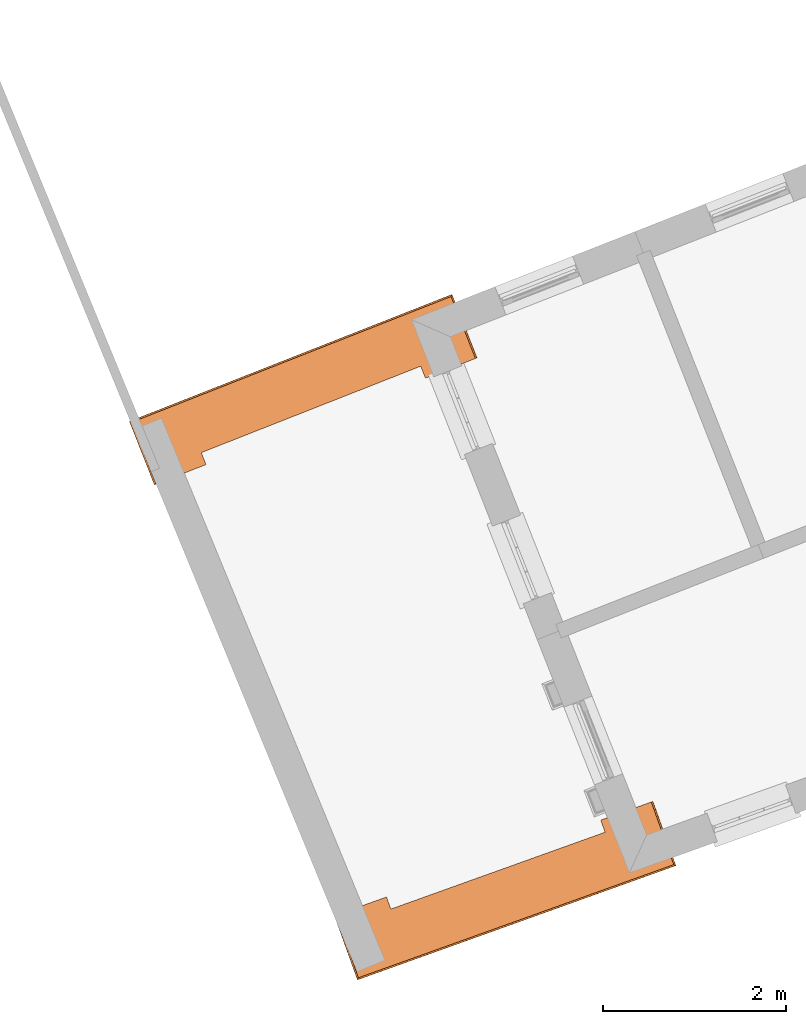
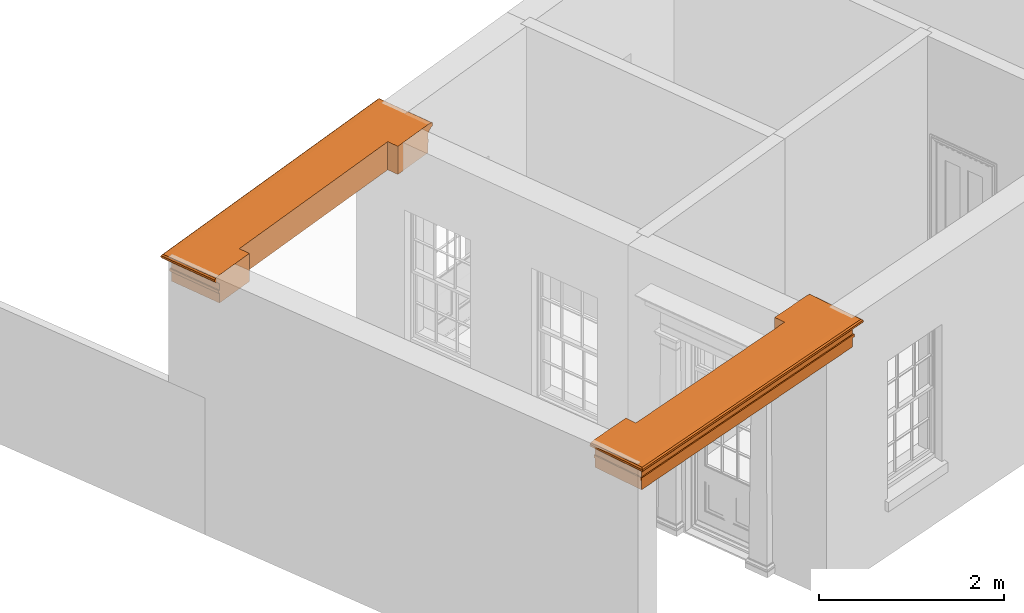
# One storey, part 8 of 8: 2 proxies.
"""IFC2X3 building model written with IfcOpenShell, lengths in metres."""

from ifc_helpers import new_model, entity, si_unit, frame, origin, place, context, subcontext, project, spatial, element, save


model = new_model("IFC2X3")

# Units and contexts
model_context = context("Model", 3, world=origin())
body_context = subcontext(model_context, "Body", "Model", "MODEL_VIEW")
ifc_project = project(units=[si_unit("PLANEANGLEUNIT", "RADIAN"), si_unit("MASSUNIT", "GRAM", prefix="KILO"), si_unit("FORCEUNIT", "NEWTON", prefix="KILO"), si_unit("LENGTHUNIT", "METRE")], contexts=[model_context])

# Site, building, storey
site_placement = place(None, origin())
site = spatial("IfcSite", under=ifc_project, at=site_placement, CompositionType="ELEMENT")
building_placement = place(None, origin())
building = spatial("IfcBuilding", under=site, at=building_placement, Name="Building plot-4", CompositionType="ELEMENT")
storey_placement = place(None, frame((0.0, 0.0, 3.0)))
storey = spatial("IfcBuildingStorey", under=building, at=storey_placement, Name="Floor 0", CompositionType="ELEMENT", Elevation=3.0)

# Proxies
proxy_1_placement = place(storey_placement, frame((0.0, 0.0, 3.45)))
axis2_placement3_d_1 = entity("IfcAxis2Placement3D", entity("IfcCartesianPoint", [0.0, 0.0, 0.0]))
element("IfcBuildingElementProxy", 1, at=proxy_1_placement, inside=storey, Name="external beam", CompositionType="ELEMENT", context=body_context, shape_type="SweptSolid", held_by="IfcProductRepresentation", body=[
    entity("IfcSurfaceCurveSweptAreaSolid", entity("IfcArbitraryClosedProfileDef", "AREA", None, entity("IfcPolyline", [entity("IfcCartesianPoint", [0.0, -0.26]), entity("IfcCartesianPoint", [-0.37, -0.26]), entity("IfcCartesianPoint", [-0.37, 0.26]), entity("IfcCartesianPoint", [-0.235, 0.26]), entity("IfcCartesianPoint", [-0.235, 0.275]), entity("IfcCartesianPoint", [-0.2, 0.275]), entity("IfcCartesianPoint", [-0.2, 0.26]), entity("IfcCartesianPoint", [-0.11, 0.26]), entity("IfcCartesianPoint", [-0.11, 0.275]), entity("IfcCartesianPoint", [-0.098, 0.278]), entity("IfcCartesianPoint", [-0.089, 0.284]), entity("IfcCartesianPoint", [-0.083, 0.293]), entity("IfcCartesianPoint", [-0.08, 0.305]), entity("IfcCartesianPoint", [-0.065, 0.305]), entity("IfcCartesianPoint", [-0.065, 0.315]), entity("IfcCartesianPoint", [-0.063, 0.326]), entity("IfcCartesianPoint", [-0.056, 0.336]), entity("IfcCartesianPoint", [-0.047, 0.343]), entity("IfcCartesianPoint", [-0.035, 0.345]), entity("IfcCartesianPoint", [-0.023, 0.343]), entity("IfcCartesianPoint", [-0.014, 0.336]), entity("IfcCartesianPoint", [-0.007, 0.326]), entity("IfcCartesianPoint", [-0.005, 0.315]), entity("IfcCartesianPoint", [0.0, 0.26]), entity("IfcCartesianPoint", [0.0, -0.26])])), axis2_placement3_d_1, entity("IfcPolyline", [entity("IfcCartesianPoint", [46.5842421733273, 45.8001744714837]), entity("IfcCartesianPoint", [46.7193228237592, 45.4236731861222]), entity("IfcCartesianPoint", [49.5445128782577, 46.4372912665733]), entity("IfcCartesianPoint", [49.4094322278257, 46.8137925519348])]), 0.0, 1.0, entity("IfcPlane", axis2_placement3_d_1)),
])
proxy_2_placement = place(storey_placement, frame((0.0, 0.0, 3.45)))
axis2_placement3_d_2 = entity("IfcAxis2Placement3D", entity("IfcCartesianPoint", [0.0, 0.0, 0.0]))
element("IfcBuildingElementProxy", 2, at=proxy_2_placement, inside=storey, Name="external beam", CompositionType="ELEMENT", context=body_context, shape_type="SweptSolid", held_by="IfcProductRepresentation", body=[
    entity("IfcSurfaceCurveSweptAreaSolid", entity("IfcArbitraryClosedProfileDef", "AREA", None, entity("IfcPolyline", [entity("IfcCartesianPoint", [0.0, -0.26]), entity("IfcCartesianPoint", [-0.37, -0.26]), entity("IfcCartesianPoint", [-0.37, 0.26]), entity("IfcCartesianPoint", [-0.235, 0.26]), entity("IfcCartesianPoint", [-0.235, 0.275]), entity("IfcCartesianPoint", [-0.2, 0.275]), entity("IfcCartesianPoint", [-0.2, 0.26]), entity("IfcCartesianPoint", [-0.11, 0.26]), entity("IfcCartesianPoint", [-0.11, 0.275]), entity("IfcCartesianPoint", [-0.098, 0.278]), entity("IfcCartesianPoint", [-0.089, 0.284]), entity("IfcCartesianPoint", [-0.083, 0.293]), entity("IfcCartesianPoint", [-0.08, 0.305]), entity("IfcCartesianPoint", [-0.065, 0.305]), entity("IfcCartesianPoint", [-0.065, 0.315]), entity("IfcCartesianPoint", [-0.063, 0.326]), entity("IfcCartesianPoint", [-0.056, 0.336]), entity("IfcCartesianPoint", [-0.047, 0.343]), entity("IfcCartesianPoint", [-0.035, 0.345]), entity("IfcCartesianPoint", [-0.023, 0.343]), entity("IfcCartesianPoint", [-0.014, 0.336]), entity("IfcCartesianPoint", [-0.007, 0.326]), entity("IfcCartesianPoint", [-0.005, 0.315]), entity("IfcCartesianPoint", [0.0, 0.26]), entity("IfcCartesianPoint", [0.0, -0.26])])), axis2_placement3_d_2, entity("IfcPolyline", [entity("IfcCartesianPoint", [47.4952299104759, 51.6407903467963]), entity("IfcCartesianPoint", [47.3486585416042, 52.0129688440622]), entity("IfcCartesianPoint", [44.4715666425688, 50.8799122566741]), entity("IfcCartesianPoint", [44.6181380114405, 50.5077337594083])]), 0.0, 1.0, entity("IfcPlane", axis2_placement3_d_2)),
])

save(model, "model.ifc")
